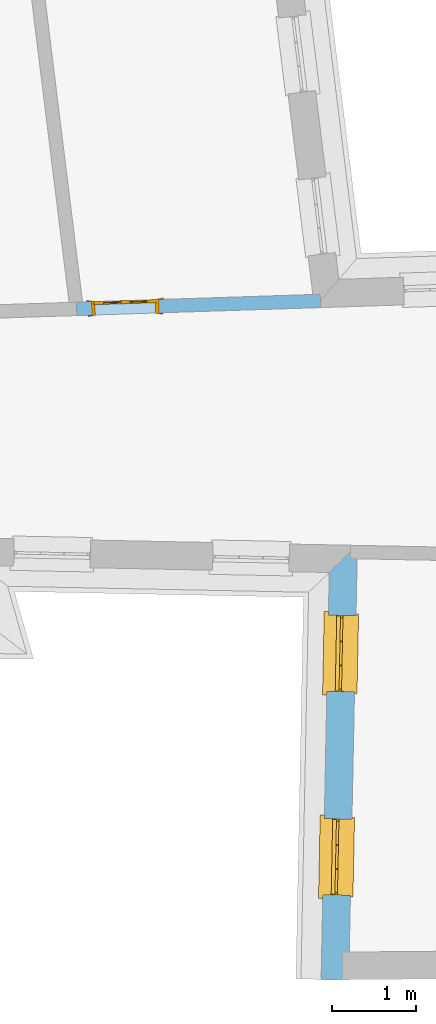
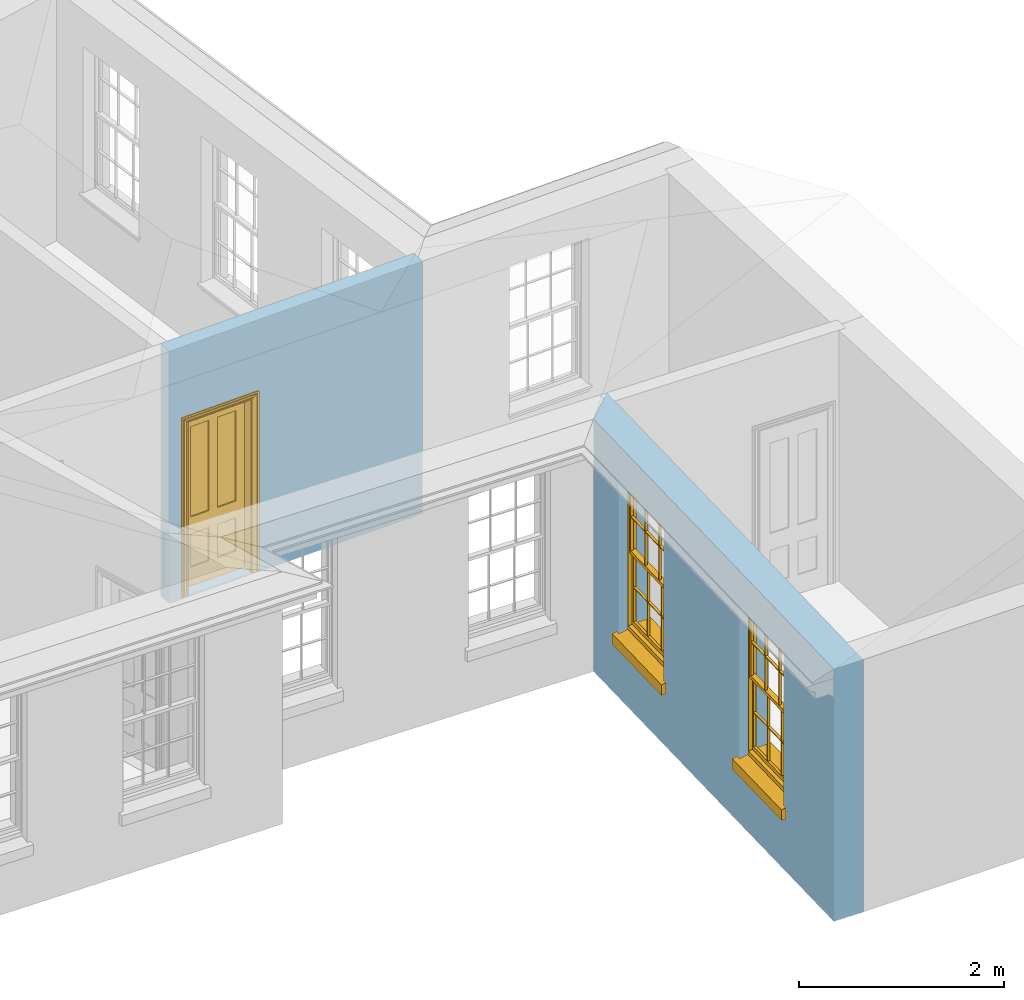
# One storey, part 5 of 11: 2 windows, 1 door, 3 openings, plus 2 elements that do not belong to this part.
"""IFC2X3 building model written with IfcOpenShell, lengths in metres."""

import ifcopenshell
import ifcopenshell.guid

model = None  # the IFC model being written
_history = None  # IfcOwnerHistory: only IFC2X3 demands one
_inside = {}  # id of a spatial element -> (the spatial element, [elements in it])
_under = {}  # id of a project, library or spatial element -> (it, [spatial elements below it])
_declared = {}  # id of a project -> (the project, [libraries it declares])
_typed = {}  # id of a type object -> (the type object, [elements of that type])
_made_of = {}  # id of a material, layer set ... -> (it, [elements and type objects made of it])


def new_model(schema):
    """Start an empty IFC model of exactly this schema.

    Asked for "IFC4X3", IfcOpenShell would pick the latest addendum, in which some entities
    have other attributes; the version numbers below select the first issue.
    IFC2X3 requires an IfcOwnerHistory on every rooted entity: one is made here for all.
    """
    global model, _history
    if schema == "IFC4X3":
        model = ifcopenshell.file(schema_version=(4, 3, 0, 0))
    else:
        model = ifcopenshell.file(schema=schema)
    _inside.clear()
    _under.clear()
    _declared.clear()
    _typed.clear()
    _made_of.clear()
    _history = None
    if model.schema == "IFC2X3":
        org = make("IfcOrganization", Name="unknown")
        user = make(
            "IfcPersonAndOrganization",
            ThePerson=make("IfcPerson", FamilyName="unknown"),
            TheOrganization=org,
        )
        app = make(
            "IfcApplication",
            ApplicationDeveloper=org,
            Version="unknown",
            ApplicationFullName="unknown",
            ApplicationIdentifier="unknown",
        )
        _history = make(
            "IfcOwnerHistory",
            OwningUser=user,
            OwningApplication=app,
            ChangeAction="ADDED",
            CreationDate=0,
        )
    return model


def make(cls, **values):
    """One entity of the class cls with the attributes given. An attribute that is None is left unset."""
    return model.create_entity(
        cls, **{name: value for name, value in values.items() if value is not None}
    )


def rooted(cls, **values):
    """An entity with a GlobalId (a new one), such as an element, a storey or a relation."""
    return make(cls, GlobalId=ifcopenshell.guid.new(), OwnerHistory=_history, **values)


def si_unit(unit_type, name, prefix=None):
    """IfcSIUnit, for example si_unit("LENGTHUNIT", "METRE", prefix="MILLI")."""
    return make("IfcSIUnit", UnitType=unit_type, Prefix=prefix, Name=name)


def assignment(units):
    """IfcUnitAssignment: the units of a project."""
    return None if units is None else make("IfcUnitAssignment", Units=units)


def point(xyz):
    """IfcCartesianPoint."""
    return None if xyz is None else make("IfcCartesianPoint", Coordinates=xyz)


def direction(xyz):
    """IfcDirection."""
    return None if xyz is None else make("IfcDirection", DirectionRatios=xyz)


def frame(location, z_axis=None, x_axis=None):
    """IfcAxis2Placement3D, a coordinate frame: its origin and axes. An axis left out is left unset."""
    return make(
        "IfcAxis2Placement3D",
        Location=point(location),
        Axis=direction(z_axis),
        RefDirection=direction(x_axis),
    )


def origin():
    """The frame at (0, 0, 0) with its axes left unset."""
    return frame((0.0, 0.0, 0.0))


def place(relative_to, where):
    """IfcLocalPlacement: puts the frame where relative to a parent placement (None: the world)."""
    return make(
        "IfcLocalPlacement", PlacementRelTo=relative_to, RelativePlacement=where
    )


def context(
    kind, dimensions, precision=None, world=None, true_north=None, identifier=None
):
    """IfcGeometricRepresentationContext, for example the 3D "Model" context."""
    return make(
        "IfcGeometricRepresentationContext",
        ContextIdentifier=identifier,
        ContextType=kind,
        CoordinateSpaceDimension=dimensions,
        Precision=precision,
        WorldCoordinateSystem=world,
        TrueNorth=true_north,
    )


def subcontext(parent, identifier, kind, view, scale=None):
    """IfcGeometricRepresentationSubContext, for example "Body" below "Model"."""
    return make(
        "IfcGeometricRepresentationSubContext",
        ContextIdentifier=identifier,
        ContextType=kind,
        ParentContext=parent,
        TargetScale=scale,
        TargetView=view,
    )


def project(units=None, contexts=None):
    """IfcProject with its units and contexts."""
    return rooted(
        "IfcProject",
        Name="project",
        RepresentationContexts=contexts,
        UnitsInContext=assignment(units),
    )


def spatial(cls, under=None, at=None, **own):
    """A site, building, storey or space (cls), placed at a placement, below another one or the project."""
    s = rooted(cls, ObjectPlacement=at, **own)
    if under is not None:
        _under.setdefault(under.id(), (under, []))[1].append(s)
    return s


def polyline(points):
    """IfcPolyline through the points."""
    return make("IfcPolyline", Points=[point(p) for p in points])


def outline(outer, holes=None, kind="AREA"):
    """IfcArbitraryClosedProfileDef: a profile drawn as a closed curve; with holes, ...WithVoids."""
    if holes is None:
        return make("IfcArbitraryClosedProfileDef", ProfileType=kind, OuterCurve=outer)
    return make(
        "IfcArbitraryProfileDefWithVoids",
        ProfileType=kind,
        OuterCurve=outer,
        InnerCurves=holes,
    )


def extrude(swept, where, along, depth):
    """IfcExtrudedAreaSolid: the profile swept, set in the frame where, extruded along a direction by depth."""
    return make(
        "IfcExtrudedAreaSolid",
        SweptArea=swept,
        Position=where,
        ExtrudedDirection=direction(along),
        Depth=depth,
    )


def faces_of(points, faces, orient=None, outer=None):
    """IfcFace entities. A face is a list of loops; a loop is a list of indices into points, from 0.

    orient and outer hold one flag for each loop. By default every Orientation is true, the
    first loop of a face is its IfcFaceOuterBound and the others are IfcFaceBound.
    """
    made = []
    for i, loops in enumerate(faces):
        bounds = []
        for j, loop in enumerate(loops):
            is_outer = j == 0 if outer is None else outer[i][j]
            bounds.append(
                make(
                    "IfcFaceOuterBound" if is_outer else "IfcFaceBound",
                    Bound=make("IfcPolyLoop", Polygon=[points[k] for k in loop]),
                    Orientation=True if orient is None else orient[i][j],
                )
            )
        made.append(make("IfcFace", Bounds=bounds))
    return made


def faceted_brep(points, faces, orient=None, outer=None, voids=None):
    """IfcFacetedBrep: a solid bounded by flat faces; with voids (closed shells), ...WithVoids."""
    shared = [point(p) for p in points]
    hull = make("IfcClosedShell", CfsFaces=faces_of(shared, faces, orient, outer))
    if voids is None:
        return make("IfcFacetedBrep", Outer=hull)
    return make(
        "IfcFacetedBrepWithVoids",
        Outer=hull,
        Voids=[
            make(cls, CfsFaces=faces_of(shared, fs, o, b)) for cls, fs, o, b in voids
        ],
    )


def shape(context_of_items, identifier, shape_type, items):
    """IfcShapeRepresentation: the items that make up one representation, for example the "Body"."""
    return make(
        "IfcShapeRepresentation",
        ContextOfItems=context_of_items,
        RepresentationIdentifier=identifier,
        RepresentationType=shape_type,
        Items=items,
    )


def material(Name=None, Category=None):
    """IfcMaterial."""
    return make("IfcMaterial", Name=Name, Category=Category)


def layer(
    of_material, thickness, ventilated=None, Name=None, Category=None, Priority=None
):
    """IfcMaterialLayer: one layer of a wall or slab, of a material (None: an air gap)."""
    return make(
        "IfcMaterialLayer",
        Material=of_material,
        LayerThickness=thickness,
        IsVentilated=ventilated,
        Name=Name,
        Category=Category,
        Priority=Priority,
    )


def layer_set(layers, Name=None):
    """IfcMaterialLayerSet."""
    return make("IfcMaterialLayerSet", MaterialLayers=layers, LayerSetName=Name)


def layer_usage(for_layer_set, set_direction, sense, offset, extent=None):
    """IfcMaterialLayerSetUsage: how a layer set lies in its element."""
    return make(
        "IfcMaterialLayerSetUsage",
        ForLayerSet=for_layer_set,
        LayerSetDirection=set_direction,
        DirectionSense=sense,
        OffsetFromReferenceLine=offset,
        ReferenceExtent=extent,
    )


def made_of(thing, what):
    """Note that an element or type object is made of a material, layer set ...; save() writes the relation."""
    if what is not None:
        _made_of.setdefault(what.id(), (what, []))[1].append(thing)
    return thing


def element(
    cls,
    number,
    at=None,
    inside=None,
    cuts=None,
    type_object=None,
    material=None,
    context=None,
    identifier="Body",
    shape_type=None,
    held_by="IfcProductDefinitionShape",
    body=None,
    shapes=None,
    **own,
):
    """One element of the class cls, such as IfcWall. Its Tag is "e" and its number.

    at: its placement. inside: the storey or other place that contains it. cuts: it is an
    opening in that element (IfcRelVoidsElement). A single representation is given by context,
    identifier, shape_type and body (its items); several are given by shapes. held_by: the class
    of the entity that holds the representations. save() writes the other relations.
    """
    e = rooted(cls, Tag="e%d" % number, ObjectPlacement=at, **own)
    if body is not None:
        shapes = [shape(context, identifier, shape_type, body)]
    if shapes is not None:
        e.Representation = make(held_by, Representations=shapes)
    if inside is not None:
        _inside.setdefault(inside.id(), (inside, []))[1].append(e)
    if cuts is not None:
        rooted(
            "IfcRelVoidsElement", RelatingBuildingElement=cuts, RelatedOpeningElement=e
        )
    if type_object is not None:
        _typed.setdefault(type_object.id(), (type_object, []))[1].append(e)
    return made_of(e, material)


def fill(opening, filler):
    """IfcRelFillsElement: the door or window that sits in an opening."""
    return rooted(
        "IfcRelFillsElement",
        RelatingOpeningElement=opening,
        RelatedBuildingElement=filler,
    )


def aggregate(whole, parts):
    """IfcRelAggregates: a whole, such as a stair, and the parts it consists of."""
    return rooted("IfcRelAggregates", RelatingObject=whole, RelatedObjects=parts)


def save(model, path):
    """Write the relations noted so far, then the file.

    IfcRelAggregates (storeys below a building ...), IfcRelContainedInSpatialStructure (elements
    in a storey), IfcRelDefinesByType, IfcRelAssociatesMaterial and IfcRelDeclares: one each for
    every whole, place, type object, material and project.
    """
    for whole, parts in _under.values():
        aggregate(whole, parts)
    for where, things in _inside.values():
        rooted(
            "IfcRelContainedInSpatialStructure",
            RelatedElements=things,
            RelatingStructure=where,
        )
    for kind, things in _typed.values():
        rooted("IfcRelDefinesByType", RelatedObjects=things, RelatingType=kind)
    for what, things in _made_of.values():
        rooted("IfcRelAssociatesMaterial", RelatedObjects=things, RelatingMaterial=what)
    for by, libraries in _declared.values():
        rooted("IfcRelDeclares", RelatingContext=by, RelatedDefinitions=libraries)
    model.write(path)


model = new_model("IFC2X3")

# Units and contexts
model_context = context("Model", 3, world=origin())
body_context = subcontext(model_context, "Body", "Model", "MODEL_VIEW")
ifc_project = project(units=[si_unit("PLANEANGLEUNIT", "RADIAN"), si_unit("MASSUNIT", "GRAM", prefix="KILO"), si_unit("FORCEUNIT", "NEWTON", prefix="KILO"), si_unit("LENGTHUNIT", "METRE")], contexts=[model_context])

# Site, building, storey
site_placement = place(None, origin())
site = spatial("IfcSite", under=ifc_project, at=site_placement, CompositionType="ELEMENT")
building_placement = place(None, origin())
building = spatial("IfcBuilding", under=site, at=building_placement, Name="Building plot-10", CompositionType="ELEMENT")
storey_placement = place(None, frame((0.0, 0.0, 4.6)))
storey = spatial("IfcBuildingStorey", under=building, at=storey_placement, Name="Floor 1", CompositionType="ELEMENT", Elevation=4.6)

# Wall, openings, windows
ifc_material_1 = material(Name="Masonry")
ifc_layer_1 = layer(ifc_material_1, 0.33, ventilated=False)
ifc_layer_set_1 = layer_set([ifc_layer_1], Name="My Wall")
ifc_layer_usage_1 = layer_usage(ifc_layer_set_1, "AXIS2", "NEGATIVE", 0.08)
wall_1_placement = place(storey_placement, origin())
wall_1 = element("IfcWallStandardCase", 1, at=wall_1_placement, inside=storey, material=ifc_layer_usage_1, Name="exterior", context=body_context, shape_type="SweptSolid", body=[
    extrude(outline(polyline([(51.0054015240496, 17.2553934156152), (50.6688922402643, 16.9320337058085), (50.5723302195108, 12.0863798802376), (50.9022647163068, 12.0798050932483), (51.0054015240496, 17.2553934156152)])), origin(), (0.0, 0.0, 1.0), 3.0),
])
opening_1_placement = place(storey_placement, frame((0.0, 0.0, 0.75)))
opening_1 = element("IfcOpeningElement", 2, at=opening_1_placement, cuts=wall_1, Name="Opening", ObjectType="Opening", context=body_context, shape_type="SweptSolid", body=[
    extrude(outline(polyline([(50.6587978709166, 16.4254803107527), (50.6406673977038, 15.5156609408), (50.9706018944998, 15.5090861538108), (50.9887323677127, 16.4189055237634), (50.6587978709166, 16.4254803107527)])), origin(), (0.0, 0.0, 1.0), 1.82),
])
opening_2_placement = place(storey_placement, frame((0.0, 0.0, 0.75)))
opening_2 = element("IfcOpeningElement", 3, at=opening_2_placement, cuts=wall_1, Name="Opening", ObjectType="Opening", context=body_context, shape_type="SweptSolid", body=[
    extrude(outline(polyline([(50.6105168605399, 14.0026533979673), (50.592386387327, 13.0928340280146), (50.922320884123, 13.0862592410253), (50.9404513573359, 13.996078610978), (50.6105168605399, 14.0026533979673)])), origin(), (0.0, 0.0, 1.0), 1.82),
])
window_1_placement = place(storey_placement, frame((50.9087482472773, 16.4204994115184, 0.75), z_axis=(0.0, 0.0, 1.0), x_axis=(-0.0181304732128567, -0.909819369952672, 0.0)))
window_1 = element("IfcWindow", 4, at=window_1_placement, inside=storey, Name="toilet outside window", OverallHeight=1.82, OverallWidth=0.91, context=body_context, shape_type="Brep", held_by="IfcProductRepresentation", body=[
    faceted_brep([(0.033125, -0.105, 0.975209), (0.01, -0.105, 0.975209), (0.033125, -0.105, 1.376042), (0.876875, -0.105, 0.975209), (0.876875, -0.105, 1.376042), (0.9, -0.105, 0.975209), (0.876875, -0.105, 1.386042), (0.876875, -0.105, 1.786875), (0.9, -0.105, 1.81), (0.033125, -0.105, 1.786875), (0.033125, -0.105, 1.386042), (0.01, -0.105, 1.81), (0.876875, -0.135, 1.376042), (0.876875, -0.135, 0.975209), (0.9, -0.135, 0.937083), (0.033125, -0.135, 1.786875), (0.01, -0.135, 1.81), (0.033125, -0.135, 1.386042), (0.01, -0.135, 0.937083), (0.033125, -0.135, 0.975209), (0.033125, -0.135, 1.376042), (0.876875, -0.135, 1.786875), (0.876875, -0.135, 1.386042), (0.9, -0.135, 1.81), (0.033125, -0.105, 0.937083), (0.01, -0.105, 0.937083), (0.033125, -0.105, 0.53625), (0.876875, -0.105, 0.937083), (0.876875, -0.105, 0.53625), (0.9, -0.105, 0.937083), (0.876875, -0.105, 0.52625), (0.876875, -0.105, 0.125417), (0.9, -0.105, 0.077167), (0.033125, -0.105, 0.125417), (0.033125, -0.105, 0.52625), (0.01, -0.105, 0.077167), (-0.0425, -0.25, 0.01), (-0.0425, -0.3, 0.001667), (0.0, -0.25, 0.01), (0.9525, -0.25, 0.01), (0.91, -0.25, 0.01), (0.9525, -0.3, 0.001667), (-0.02, 0.08, 0.077167), (0.0, 0.08, 0.077167), (-0.02, 0.11, 0.077167), (0.0, -0.06, 0.077167), (0.01, -0.06, 0.077167), (0.91, -0.06, 0.077167), (0.91, 0.08, 0.077167), (0.9, -0.06, 0.077167), (0.93, 0.08, 0.077167), (0.93, 0.11, 0.077167), (0.01, -0.075, 0.975209), (0.9, -0.075, 0.975209), (0.876875, -0.075, 0.125417), (0.876875, -0.075, 0.52625), (0.9, -0.075, 0.077167), (0.876875, -0.075, 0.53625), (0.876875, -0.075, 0.937083), (0.033125, -0.075, 0.125417), (0.01, -0.075, 0.077167), (0.033125, -0.075, 0.52625), (0.033125, -0.075, 0.937083), (0.033125, -0.075, 0.53625), (-0.02, 0.08, 0.052167), (-0.02, 0.11, 0.052167), (0.93, 0.11, 0.052167), (0.93, 0.08, 0.052167), (0.91, 0.08, 0.052167), (0.0, 0.08, 0.052167), (0.91, -0.15, 0.026667), (0.0, -0.15, 0.026667), (-0.0425, -0.3, -0.123333), (0.9525, -0.3, -0.123333), (-0.0425, -0.25, -0.123333), (0.9525, -0.25, -0.123333), (0.01, -0.06, 1.81), (0.9, -0.06, 1.81), (0.0, -0.06, 1.82), (0.91, -0.06, 1.82), (0.01, -0.15, 0.077167), (0.9, -0.15, 0.077167), (0.592292, -0.105, 0.125417), (0.592292, -0.075, 0.125417), (0.317708, -0.075, 0.125417), (0.317708, -0.105, 0.125417), (0.592292, -0.105, 0.53625), (0.317708, -0.105, 0.53625), (0.317708, -0.105, 0.52625), (0.592292, -0.105, 0.52625), (0.592292, -0.075, 0.53625), (0.317708, -0.075, 0.53625), (0.592292, -0.135, 1.386042), (0.592292, -0.105, 1.386042), (0.317708, -0.105, 1.386042), (0.317708, -0.135, 1.386042), (0.317708, -0.135, 1.376042), (0.592292, -0.135, 1.376042), (0.317708, -0.105, 1.376042), (0.592292, -0.105, 1.376042), (0.602292, -0.135, 1.376042), (0.592292, -0.135, 0.975209), (0.602292, -0.135, 0.975209), (0.602292, -0.105, 0.975209), (0.592292, -0.105, 0.975209), (0.602292, -0.105, 1.376042), (0.602292, -0.075, 0.53625), (0.602292, -0.105, 0.53625), (0.317708, -0.075, 0.52625), (0.307708, -0.075, 0.125417), (0.307708, -0.075, 0.52625), (0.602292, -0.075, 0.52625), (0.602292, -0.075, 0.125417), (0.592292, -0.075, 0.52625), (0.307708, -0.075, 0.53625), (0.317708, -0.075, 0.937083), (0.307708, -0.075, 0.937083), (0.602292, -0.075, 0.937083), (0.592292, -0.075, 0.937083), (0.307708, -0.105, 0.52625), (0.307708, -0.105, 0.125417), (0.307708, -0.105, 0.53625), (0.307708, -0.105, 0.937083), (0.592292, -0.105, 0.937083), (0.317708, -0.105, 0.937083), (0.602292, -0.105, 0.937083), (0.602292, -0.105, 0.52625), (0.602292, -0.105, 0.125417), (0.307708, -0.135, 1.386042), (0.307708, -0.135, 1.376042), (0.307708, -0.135, 0.975209), (0.317708, -0.135, 0.975209), (0.317708, -0.135, 1.786875), (0.307708, -0.135, 1.786875), (0.602292, -0.135, 1.786875), (0.592292, -0.135, 1.786875), (0.602292, -0.135, 1.386042), (0.602292, -0.105, 1.386042), (0.307708, -0.105, 1.386042), (0.307708, -0.105, 1.786875), (0.317708, -0.105, 1.786875), (0.592292, -0.105, 1.786875), (0.602292, -0.105, 1.786875), (0.307708, -0.105, 1.376042), (0.317708, -0.105, 0.975209), (0.307708, -0.105, 0.975209), (0.91, -0.15, 1.82), (0.9, -0.15, 1.81), (0.01, -0.15, 1.81), (0.0, -0.15, 1.82), (0.91, -0.25, 0.0), (0.0, -0.25, 0.0), (0.91, 0.08, 0.0), (0.0, 0.08, 0.0)], [[[0, 1, 2]], [[3, 4, 5]], [[6, 7, 8]], [[9, 10, 11]], [[12, 13, 14]], [[15, 16, 17]], [[18, 19, 20]], [[21, 22, 23]], [[24, 25, 26]], [[27, 28, 29]], [[30, 31, 32]], [[33, 34, 35]], [[14, 27, 29]], [[25, 24, 18]], [[36, 37, 38]], [[39, 40, 41]], [[42, 43, 44]], [[45, 46, 43]], [[47, 48, 49]], [[50, 51, 48]], [[1, 0, 52]], [[5, 53, 3]], [[54, 55, 56]], [[57, 58, 53]], [[59, 60, 61]], [[62, 63, 52]], [[48, 43, 46, 49]], [[51, 44, 43, 48]], [[64, 42, 44, 65]], [[65, 44, 51, 66]], [[66, 51, 50, 67]], [[65, 66, 68, 69]], [[60, 56, 49, 46]], [[70, 71, 38, 40]], [[37, 41, 40, 38]], [[37, 72, 73, 41]], [[74, 75, 73, 72]], [[8, 11, 76, 77]], [[76, 78, 79, 77]], [[32, 35, 80, 81]], [[81, 80, 71, 70]], [[82, 83, 84, 85]], [[86, 87, 88, 89]], [[86, 90, 91, 87]], [[92, 93, 94, 95]], [[92, 95, 96, 97]], [[96, 98, 99, 97]], [[100, 97, 101, 102]], [[103, 104, 99, 105]], [[97, 99, 104, 101]], [[102, 103, 105, 100]], [[28, 57, 106, 107]], [[108, 84, 109, 110]], [[111, 112, 83, 113]], [[114, 110, 61, 63]], [[90, 113, 108, 91]], [[115, 91, 114, 116]], [[117, 106, 90, 118]], [[111, 106, 57, 55]], [[119, 110, 109, 120]], [[34, 61, 110, 119]], [[89, 113, 83, 82]], [[88, 108, 113, 89]], [[85, 84, 108, 88]], [[121, 114, 63, 26]], [[122, 116, 114, 121]], [[123, 118, 90, 86]], [[87, 91, 115, 124]], [[107, 106, 117, 125]], [[126, 111, 55, 30]], [[127, 112, 111, 126]], [[126, 30, 28, 107]], [[88, 119, 120, 85]], [[126, 89, 82, 127]], [[125, 123, 86, 107]], [[121, 26, 34, 119]], [[124, 122, 121, 87]], [[128, 17, 20, 129]], [[96, 129, 130, 131]], [[132, 133, 128, 95]], [[134, 135, 92, 136]], [[100, 12, 22, 136]], [[137, 6, 4, 105]], [[94, 138, 139, 140]], [[137, 93, 141, 142]], [[99, 98, 94, 93]], [[143, 2, 10, 138]], [[144, 145, 143, 98]], [[129, 143, 145, 130]], [[20, 2, 143, 129]], [[131, 144, 98, 96]], [[128, 138, 10, 17]], [[133, 139, 138, 128]], [[135, 141, 93, 92]], [[95, 94, 140, 132]], [[22, 6, 137, 136]], [[136, 137, 142, 134]], [[100, 105, 4, 12]], [[107, 86, 89, 126]], [[106, 111, 113, 90]], [[91, 108, 110, 114]], [[87, 121, 119, 88]], [[97, 100, 136, 92]], [[129, 96, 95, 128]], [[98, 143, 138, 94]], [[105, 99, 93, 137]], [[131, 101, 104, 144]], [[124, 115, 118, 123]], [[132, 140, 141, 135]], [[120, 109, 59, 33]], [[15, 9, 139, 133]], [[134, 142, 7, 21]], [[31, 54, 112, 127]], [[36, 74, 72, 37]], [[39, 41, 73, 75]], [[18, 14, 101, 131]], [[23, 16, 132, 135]], [[83, 56, 60, 84]], [[52, 53, 118, 115]], [[53, 52, 144, 104]], [[11, 8, 141, 140]], [[14, 18, 124, 123]], [[2, 1, 11, 10]], [[8, 5, 4, 6]], [[57, 53, 56, 55]], [[60, 52, 63, 61]], [[26, 25, 35, 34]], [[32, 29, 28, 30]], [[14, 23, 22, 12]], [[18, 20, 17, 16]], [[19, 0, 2, 20]], [[17, 10, 9, 15]], [[12, 4, 3, 13]], [[21, 7, 6, 22]], [[27, 58, 57, 28]], [[30, 55, 54, 31]], [[33, 59, 61, 34]], [[26, 63, 62, 24]], [[5, 8, 77, 53]], [[76, 11, 1, 52]], [[46, 45, 78, 76]], [[49, 77, 79, 47]], [[70, 146, 147, 81]], [[71, 80, 148, 149]], [[19, 130, 145, 0]], [[102, 13, 3, 103]], [[116, 122, 24, 62]], [[29, 32, 81, 14]], [[80, 35, 25, 18]], [[60, 46, 76, 52]], [[77, 49, 56, 53]], [[23, 14, 81, 147]], [[16, 148, 80, 18]], [[35, 85, 120]], [[120, 33, 35]], [[127, 82, 32]], [[32, 31, 127]], [[32, 82, 85, 35]], [[102, 101, 14]], [[14, 13, 102]], [[18, 131, 130]], [[130, 19, 18]], [[134, 21, 23]], [[23, 135, 134]], [[16, 15, 133]], [[133, 132, 16]], [[11, 140, 139]], [[139, 9, 11]], [[142, 141, 8]], [[8, 7, 142]], [[23, 147, 148, 16]], [[146, 149, 148, 147]], [[52, 115, 116]], [[116, 62, 52]], [[118, 53, 117]], [[58, 117, 53]], [[27, 125, 117, 58]], [[56, 83, 112]], [[112, 54, 56]], [[109, 84, 60]], [[60, 59, 109]], [[125, 27, 14]], [[14, 123, 125]], [[122, 124, 18]], [[18, 24, 122]], [[145, 144, 52]], [[52, 0, 145]], [[103, 3, 53]], [[53, 104, 103]], [[79, 78, 149, 146]], [[78, 45, 71, 149]], [[146, 70, 47, 79]], [[150, 75, 74, 151]], [[68, 66, 67]], [[48, 68, 67, 50]], [[69, 64, 65]], [[42, 64, 69, 43]], [[69, 68, 152, 153]], [[70, 68, 48, 47]], [[150, 152, 68, 70]], [[43, 69, 71, 45]], [[69, 153, 151, 71]], [[152, 150, 151, 153]], [[38, 151, 74, 36]], [[71, 151, 38]], [[39, 75, 150, 40]], [[40, 150, 70]]]),
])
fill(opening_1, window_1)
window_2_placement = place(storey_placement, frame((50.8604672369005, 13.997672498733, 0.75), z_axis=(0.0, 0.0, 1.0), x_axis=(-0.0181304732128567, -0.909819369952672, 0.0)))
window_2 = element("IfcWindow", 5, at=window_2_placement, inside=storey, Name="toilet outside window", OverallHeight=1.82, OverallWidth=0.91, context=body_context, shape_type="Brep", held_by="IfcProductRepresentation", body=[
    faceted_brep([(0.033125, -0.105, 0.975209), (0.01, -0.105, 0.975209), (0.033125, -0.105, 1.376042), (0.876875, -0.105, 0.975209), (0.876875, -0.105, 1.376042), (0.9, -0.105, 0.975209), (0.876875, -0.105, 1.386042), (0.876875, -0.105, 1.786875), (0.9, -0.105, 1.81), (0.033125, -0.105, 1.786875), (0.033125, -0.105, 1.386042), (0.01, -0.105, 1.81), (0.876875, -0.135, 1.376042), (0.876875, -0.135, 0.975209), (0.9, -0.135, 0.937083), (0.033125, -0.135, 1.786875), (0.01, -0.135, 1.81), (0.033125, -0.135, 1.386042), (0.01, -0.135, 0.937083), (0.033125, -0.135, 0.975209), (0.033125, -0.135, 1.376042), (0.876875, -0.135, 1.786875), (0.876875, -0.135, 1.386042), (0.9, -0.135, 1.81), (0.033125, -0.105, 0.937083), (0.01, -0.105, 0.937083), (0.033125, -0.105, 0.53625), (0.876875, -0.105, 0.937083), (0.876875, -0.105, 0.53625), (0.9, -0.105, 0.937083), (0.876875, -0.105, 0.52625), (0.876875, -0.105, 0.125417), (0.9, -0.105, 0.077167), (0.033125, -0.105, 0.125417), (0.033125, -0.105, 0.52625), (0.01, -0.105, 0.077167), (-0.0425, -0.25, 0.01), (-0.0425, -0.3, 0.001667), (0.0, -0.25, 0.01), (0.9525, -0.25, 0.01), (0.91, -0.25, 0.01), (0.9525, -0.3, 0.001667), (-0.02, 0.08, 0.077167), (0.0, 0.08, 0.077167), (-0.02, 0.11, 0.077167), (0.0, -0.06, 0.077167), (0.01, -0.06, 0.077167), (0.91, -0.06, 0.077167), (0.91, 0.08, 0.077167), (0.9, -0.06, 0.077167), (0.93, 0.08, 0.077167), (0.93, 0.11, 0.077167), (0.01, -0.075, 0.975209), (0.9, -0.075, 0.975209), (0.876875, -0.075, 0.125417), (0.876875, -0.075, 0.52625), (0.9, -0.075, 0.077167), (0.876875, -0.075, 0.53625), (0.876875, -0.075, 0.937083), (0.033125, -0.075, 0.125417), (0.01, -0.075, 0.077167), (0.033125, -0.075, 0.52625), (0.033125, -0.075, 0.937083), (0.033125, -0.075, 0.53625), (-0.02, 0.08, 0.052167), (-0.02, 0.11, 0.052167), (0.93, 0.11, 0.052167), (0.93, 0.08, 0.052167), (0.91, 0.08, 0.052167), (0.0, 0.08, 0.052167), (0.91, -0.15, 0.026667), (0.0, -0.15, 0.026667), (-0.0425, -0.3, -0.123333), (0.9525, -0.3, -0.123333), (-0.0425, -0.25, -0.123333), (0.9525, -0.25, -0.123333), (0.01, -0.06, 1.81), (0.9, -0.06, 1.81), (0.0, -0.06, 1.82), (0.91, -0.06, 1.82), (0.01, -0.15, 0.077167), (0.9, -0.15, 0.077167), (0.592292, -0.105, 0.125417), (0.592292, -0.075, 0.125417), (0.317708, -0.075, 0.125417), (0.317708, -0.105, 0.125417), (0.592292, -0.105, 0.53625), (0.317708, -0.105, 0.53625), (0.317708, -0.105, 0.52625), (0.592292, -0.105, 0.52625), (0.592292, -0.075, 0.53625), (0.317708, -0.075, 0.53625), (0.592292, -0.135, 1.386042), (0.592292, -0.105, 1.386042), (0.317708, -0.105, 1.386042), (0.317708, -0.135, 1.386042), (0.317708, -0.135, 1.376042), (0.592292, -0.135, 1.376042), (0.317708, -0.105, 1.376042), (0.592292, -0.105, 1.376042), (0.602292, -0.135, 1.376042), (0.592292, -0.135, 0.975209), (0.602292, -0.135, 0.975209), (0.602292, -0.105, 0.975209), (0.592292, -0.105, 0.975209), (0.602292, -0.105, 1.376042), (0.602292, -0.075, 0.53625), (0.602292, -0.105, 0.53625), (0.317708, -0.075, 0.52625), (0.307708, -0.075, 0.125417), (0.307708, -0.075, 0.52625), (0.602292, -0.075, 0.52625), (0.602292, -0.075, 0.125417), (0.592292, -0.075, 0.52625), (0.307708, -0.075, 0.53625), (0.317708, -0.075, 0.937083), (0.307708, -0.075, 0.937083), (0.602292, -0.075, 0.937083), (0.592292, -0.075, 0.937083), (0.307708, -0.105, 0.52625), (0.307708, -0.105, 0.125417), (0.307708, -0.105, 0.53625), (0.307708, -0.105, 0.937083), (0.592292, -0.105, 0.937083), (0.317708, -0.105, 0.937083), (0.602292, -0.105, 0.937083), (0.602292, -0.105, 0.52625), (0.602292, -0.105, 0.125417), (0.307708, -0.135, 1.386042), (0.307708, -0.135, 1.376042), (0.307708, -0.135, 0.975209), (0.317708, -0.135, 0.975209), (0.317708, -0.135, 1.786875), (0.307708, -0.135, 1.786875), (0.602292, -0.135, 1.786875), (0.592292, -0.135, 1.786875), (0.602292, -0.135, 1.386042), (0.602292, -0.105, 1.386042), (0.307708, -0.105, 1.386042), (0.307708, -0.105, 1.786875), (0.317708, -0.105, 1.786875), (0.592292, -0.105, 1.786875), (0.602292, -0.105, 1.786875), (0.307708, -0.105, 1.376042), (0.317708, -0.105, 0.975209), (0.307708, -0.105, 0.975209), (0.91, -0.15, 1.82), (0.9, -0.15, 1.81), (0.01, -0.15, 1.81), (0.0, -0.15, 1.82), (0.91, -0.25, 0.0), (0.0, -0.25, 0.0), (0.91, 0.08, 0.0), (0.0, 0.08, 0.0)], [[[0, 1, 2]], [[3, 4, 5]], [[6, 7, 8]], [[9, 10, 11]], [[12, 13, 14]], [[15, 16, 17]], [[18, 19, 20]], [[21, 22, 23]], [[24, 25, 26]], [[27, 28, 29]], [[30, 31, 32]], [[33, 34, 35]], [[14, 27, 29]], [[25, 24, 18]], [[36, 37, 38]], [[39, 40, 41]], [[42, 43, 44]], [[45, 46, 43]], [[47, 48, 49]], [[50, 51, 48]], [[1, 0, 52]], [[5, 53, 3]], [[54, 55, 56]], [[57, 58, 53]], [[59, 60, 61]], [[62, 63, 52]], [[48, 43, 46, 49]], [[51, 44, 43, 48]], [[64, 42, 44, 65]], [[65, 44, 51, 66]], [[66, 51, 50, 67]], [[65, 66, 68, 69]], [[60, 56, 49, 46]], [[70, 71, 38, 40]], [[37, 41, 40, 38]], [[37, 72, 73, 41]], [[74, 75, 73, 72]], [[8, 11, 76, 77]], [[76, 78, 79, 77]], [[32, 35, 80, 81]], [[81, 80, 71, 70]], [[82, 83, 84, 85]], [[86, 87, 88, 89]], [[86, 90, 91, 87]], [[92, 93, 94, 95]], [[92, 95, 96, 97]], [[96, 98, 99, 97]], [[100, 97, 101, 102]], [[103, 104, 99, 105]], [[97, 99, 104, 101]], [[102, 103, 105, 100]], [[28, 57, 106, 107]], [[108, 84, 109, 110]], [[111, 112, 83, 113]], [[114, 110, 61, 63]], [[90, 113, 108, 91]], [[115, 91, 114, 116]], [[117, 106, 90, 118]], [[111, 106, 57, 55]], [[119, 110, 109, 120]], [[34, 61, 110, 119]], [[89, 113, 83, 82]], [[88, 108, 113, 89]], [[85, 84, 108, 88]], [[121, 114, 63, 26]], [[122, 116, 114, 121]], [[123, 118, 90, 86]], [[87, 91, 115, 124]], [[107, 106, 117, 125]], [[126, 111, 55, 30]], [[127, 112, 111, 126]], [[126, 30, 28, 107]], [[88, 119, 120, 85]], [[126, 89, 82, 127]], [[125, 123, 86, 107]], [[121, 26, 34, 119]], [[124, 122, 121, 87]], [[128, 17, 20, 129]], [[96, 129, 130, 131]], [[132, 133, 128, 95]], [[134, 135, 92, 136]], [[100, 12, 22, 136]], [[137, 6, 4, 105]], [[94, 138, 139, 140]], [[137, 93, 141, 142]], [[99, 98, 94, 93]], [[143, 2, 10, 138]], [[144, 145, 143, 98]], [[129, 143, 145, 130]], [[20, 2, 143, 129]], [[131, 144, 98, 96]], [[128, 138, 10, 17]], [[133, 139, 138, 128]], [[135, 141, 93, 92]], [[95, 94, 140, 132]], [[22, 6, 137, 136]], [[136, 137, 142, 134]], [[100, 105, 4, 12]], [[107, 86, 89, 126]], [[106, 111, 113, 90]], [[91, 108, 110, 114]], [[87, 121, 119, 88]], [[97, 100, 136, 92]], [[129, 96, 95, 128]], [[98, 143, 138, 94]], [[105, 99, 93, 137]], [[131, 101, 104, 144]], [[124, 115, 118, 123]], [[132, 140, 141, 135]], [[120, 109, 59, 33]], [[15, 9, 139, 133]], [[134, 142, 7, 21]], [[31, 54, 112, 127]], [[36, 74, 72, 37]], [[39, 41, 73, 75]], [[18, 14, 101, 131]], [[23, 16, 132, 135]], [[83, 56, 60, 84]], [[52, 53, 118, 115]], [[53, 52, 144, 104]], [[11, 8, 141, 140]], [[14, 18, 124, 123]], [[2, 1, 11, 10]], [[8, 5, 4, 6]], [[57, 53, 56, 55]], [[60, 52, 63, 61]], [[26, 25, 35, 34]], [[32, 29, 28, 30]], [[14, 23, 22, 12]], [[18, 20, 17, 16]], [[19, 0, 2, 20]], [[17, 10, 9, 15]], [[12, 4, 3, 13]], [[21, 7, 6, 22]], [[27, 58, 57, 28]], [[30, 55, 54, 31]], [[33, 59, 61, 34]], [[26, 63, 62, 24]], [[5, 8, 77, 53]], [[76, 11, 1, 52]], [[46, 45, 78, 76]], [[49, 77, 79, 47]], [[70, 146, 147, 81]], [[71, 80, 148, 149]], [[19, 130, 145, 0]], [[102, 13, 3, 103]], [[116, 122, 24, 62]], [[29, 32, 81, 14]], [[80, 35, 25, 18]], [[60, 46, 76, 52]], [[77, 49, 56, 53]], [[23, 14, 81, 147]], [[16, 148, 80, 18]], [[35, 85, 120]], [[120, 33, 35]], [[127, 82, 32]], [[32, 31, 127]], [[32, 82, 85, 35]], [[102, 101, 14]], [[14, 13, 102]], [[18, 131, 130]], [[130, 19, 18]], [[134, 21, 23]], [[23, 135, 134]], [[16, 15, 133]], [[133, 132, 16]], [[11, 140, 139]], [[139, 9, 11]], [[142, 141, 8]], [[8, 7, 142]], [[23, 147, 148, 16]], [[146, 149, 148, 147]], [[52, 115, 116]], [[116, 62, 52]], [[118, 53, 117]], [[58, 117, 53]], [[27, 125, 117, 58]], [[56, 83, 112]], [[112, 54, 56]], [[109, 84, 60]], [[60, 59, 109]], [[125, 27, 14]], [[14, 123, 125]], [[122, 124, 18]], [[18, 24, 122]], [[145, 144, 52]], [[52, 0, 145]], [[103, 3, 53]], [[53, 104, 103]], [[79, 78, 149, 146]], [[78, 45, 71, 149]], [[146, 70, 47, 79]], [[150, 75, 74, 151]], [[68, 66, 67]], [[48, 68, 67, 50]], [[69, 64, 65]], [[42, 64, 69, 43]], [[69, 68, 152, 153]], [[70, 68, 48, 47]], [[150, 152, 68, 70]], [[43, 69, 71, 45]], [[69, 153, 151, 71]], [[152, 150, 151, 153]], [[38, 151, 74, 36]], [[71, 151, 38]], [[39, 75, 150, 40]], [[40, 150, 70]]]),
])
fill(opening_2, window_2)

# Wall, opening, door
ifc_material_2 = material(Name="Masonry")
ifc_layer_2 = layer(ifc_material_2, 0.16, ventilated=False)
ifc_layer_set_2 = layer_set([ifc_layer_2], Name="My Wall")
ifc_layer_usage_2 = layer_usage(ifc_layer_set_2, "AXIS2", "NEGATIVE", 0.08)
wall_2_placement = place(storey_placement, origin())
wall_2 = element("IfcWallStandardCase", 6, at=wall_2_placement, inside=storey, material=ifc_layer_usage_2, Name="interior", context=body_context, shape_type="SweptSolid", body=[
    extrude(outline(polyline([(47.658622031028, 20.152054432623), (47.6638318559474, 19.9921392747288), (50.566878828731, 20.0867167160446), (50.5616690038116, 20.2466318739388), (47.658622031028, 20.152054432623)])), origin(), (0.0, 0.0, 1.0), 3.0),
])
opening_3_placement = place(storey_placement, frame((0.0, 0.0, 0.0199999999999996)))
opening_3 = element("IfcOpeningElement", 7, at=opening_3_placement, cuts=wall_2, Name="Opening", ObjectType="Opening", context=body_context, shape_type="SweptSolid", body=[
    extrude(outline(polyline([(47.8437364085784, 19.9980003277633), (48.6433121980491, 20.0240494523607), (48.6381023731296, 20.1839646102548), (47.8385265836589, 20.1579154856574), (47.8437364085784, 19.9980003277633)])), origin(), (0.0, 0.0, 1.0), 2.1),
])
door_placement = place(storey_placement, frame((47.8411314961186, 20.0779579067103, 0.0199999999999996), z_axis=(0.0, 0.0, 1.0), x_axis=(0.799575789470708, 0.0260491245974208, 0.0)))
door = element("IfcDoor", 8, at=door_placement, inside=storey, Name="bedroom inside door", OverallHeight=2.1, OverallWidth=0.8, context=body_context, shape_type="Brep", held_by="IfcProductRepresentation", body=[
    faceted_brep([(0.773, 0.08, 1.895), (0.66, 0.08, 1.895), (0.66, 0.08, 2.073), (0.773, 0.08, 2.073), (0.773, 0.08, 0.82), (0.66, 0.08, 0.82), (0.45, 0.08, 1.895), (0.45, 0.08, 2.073), (0.773, 0.08, 0.62), (0.66, 0.08, 0.62), (0.66, 0.065, 0.82), (0.66, 0.065, 1.895), (0.45, 0.065, 1.895), (0.35, 0.08, 1.895), (0.35, 0.08, 2.073), (0.773, 0.08, 0.225), (0.66, 0.08, 0.225), (0.45, 0.08, 0.62), (0.45, 0.08, 0.82), (0.45, 0.065, 0.82), (0.35, 0.08, 0.82), (0.14, 0.08, 2.073), (0.14, 0.08, 1.895), (0.773, 0.08, 0.0), (0.66, 0.08, 0.0), (0.66, 0.065, 0.225), (0.66, 0.065, 0.62), (0.45, 0.065, 0.62), (0.35, 0.08, 0.62), (0.35, 0.065, 0.82), (0.35, 0.065, 1.895), (0.14, 0.065, 1.895), (0.027, 0.08, 2.073), (0.027, 0.08, 1.895), (0.773, 0.042, 0.0), (0.66, 0.042, 0.0), (0.45, 0.08, 0.0), (0.45, 0.08, 0.225), (0.45, 0.065, 0.225), (0.35, 0.08, 0.225), (0.14, 0.08, 0.82), (0.14, 0.08, 0.62), (0.14, 0.065, 0.82), (0.027, 0.08, 0.82), (0.773, 0.042, 0.225), (0.66, 0.042, 0.225), (0.45, 0.042, 0.0), (0.35, 0.08, 0.0), (0.35, 0.065, 0.225), (0.35, 0.065, 0.62), (0.14, 0.065, 0.62), (0.027, 0.08, 0.62), (0.773, 0.042, 0.62), (0.66, 0.042, 0.62), (0.45, 0.042, 0.225), (0.35, 0.042, 0.0), (0.14, 0.08, 0.225), (0.14, 0.08, 0.0), (0.14, 0.065, 0.225), (0.027, 0.08, 0.225), (0.773, 0.042, 0.82), (0.66, 0.042, 0.82), (0.66, 0.057, 0.62), (0.66, 0.057, 0.225), (0.45, 0.057, 0.225), (0.35, 0.042, 0.225), (0.14, 0.042, 0.0), (0.027, 0.08, 0.0), (0.773, 0.042, 1.895), (0.66, 0.042, 1.895), (0.45, 0.042, 0.62), (0.45, 0.042, 0.82), (0.45, 0.057, 0.62), (0.35, 0.042, 0.62), (0.14, 0.042, 0.225), (0.027, 0.042, 0.0), (0.773, 0.042, 2.073), (0.66, 0.042, 2.073), (0.66, 0.057, 1.895), (0.66, 0.057, 0.82), (0.45, 0.057, 0.82), (0.35, 0.042, 0.82), (0.35, 0.057, 0.62), (0.35, 0.057, 0.225), (0.14, 0.057, 0.225), (0.027, 0.042, 0.225), (0.45, 0.042, 1.895), (0.45, 0.042, 2.073), (0.45, 0.057, 1.895), (0.35, 0.042, 1.895), (0.14, 0.042, 0.82), (0.14, 0.042, 0.62), (0.14, 0.057, 0.62), (0.027, 0.042, 0.62), (0.35, 0.042, 2.073), (0.35, 0.057, 1.895), (0.35, 0.057, 0.82), (0.14, 0.057, 0.82), (0.027, 0.042, 0.82), (0.14, 0.042, 2.073), (0.14, 0.042, 1.895), (0.14, 0.057, 1.895), (0.027, 0.042, 1.895), (0.027, 0.042, 2.073), (0.02, 0.085, 0.0), (0.005, 0.09, 0.0), (0.005, 0.09, 2.095), (0.02, 0.085, 2.08), (0.02, 0.08, 0.0), (0.0, 0.085, 0.0), (0.0, 0.085, 2.1), (0.795, 0.09, 2.095), (0.78, 0.085, 2.08), (0.02, 0.08, 2.08), (0.0, 0.08, 0.0), (-0.032, 0.095, 0.0), (-0.032, 0.095, 2.132), (0.8, 0.085, 2.1), (0.795, 0.09, 0.0), (0.78, 0.085, 0.0), (0.78, 0.08, 2.08), (0.04, 0.04, 0.0), (0.025, 0.04, 0.0), (0.025, 0.04, 2.075), (0.04, 0.04, 2.06), (-0.04, 0.09, 0.0), (-0.04, 0.09, 2.14), (0.832, 0.095, 2.132), (0.8, 0.085, 0.0), (0.78, 0.08, 0.0), (0.8, 0.08, 0.0), (0.86, 0.08, 0.0), (0.86, 0.08, 2.16), (0.8, 0.08, 2.1), (-0.06, 0.08, 2.16), (0.0, 0.08, 2.1), (-0.06, 0.08, 0.0), (-0.04, 0.095, 0.0), (-0.04, 0.095, 2.14), (0.84, 0.09, 2.14), (0.832, 0.095, 0.0), (0.84, 0.09, 0.0), (0.86, 0.095, 0.0), (0.86, 0.095, 2.16), (-0.06, 0.095, 2.16), (-0.06, 0.095, 0.0), (0.84, 0.095, 0.0), (0.84, 0.095, 2.14), (-0.025, -0.095, 0.0), (-0.025, -0.09, 0.0), (-0.025, -0.09, 2.125), (-0.025, -0.095, 2.125), (-0.017, -0.095, 0.0), (-0.017, -0.095, 2.117), (0.825, -0.09, 2.125), (0.825, -0.095, 2.125), (0.825, -0.095, 0.0), (0.845, -0.095, 0.0), (-0.045, -0.095, 2.145), (-0.045, -0.095, 0.0), (0.845, -0.095, 2.145), (0.015, -0.085, 0.0), (0.015, -0.085, 2.085), (0.817, -0.095, 2.117), (0.825, -0.09, 0.0), (0.845, -0.08, 0.0), (0.845, -0.08, 2.145), (-0.045, -0.08, 2.145), (-0.045, -0.08, 0.0), (0.02, -0.09, 0.0), (0.02, -0.09, 2.08), (0.785, -0.085, 2.085), (0.817, -0.095, 0.0), (0.8, -0.08, 0.0), (0.8, -0.08, 2.1), (0.0, -0.08, 2.1), (0.0, -0.08, 0.0), (0.035, -0.085, 0.0), (0.035, -0.085, 2.065), (0.78, -0.09, 2.08), (0.785, -0.085, 0.0), (0.775, 0.04, 2.075), (0.76, 0.04, 2.06), (0.035, -0.08, 2.065), (0.035, -0.08, 0.0), (0.765, -0.085, 2.065), (0.78, -0.09, 0.0), (0.765, -0.08, 0.0), (0.765, -0.08, 2.065), (0.765, -0.085, 0.0), (0.04, -0.08, 2.06), (0.04, -0.08, 0.0), (0.76, -0.08, 2.06), (0.76, -0.08, 0.0), (0.76, 0.04, 0.0), (0.775, 0.04, 0.0), (0.025, 0.08, 0.0), (0.025, 0.08, 2.075), (0.775, 0.08, 0.0), (0.775, 0.08, 2.075)], [[[0, 1, 2, 3]], [[1, 0, 4, 5]], [[1, 6, 7, 2]], [[8, 9, 5, 4]], [[1, 5, 10, 11]], [[6, 1, 11, 12]], [[6, 13, 14, 7]], [[15, 16, 9, 8]], [[9, 17, 18, 5]], [[5, 18, 19, 10]], [[10, 19, 12, 11]], [[18, 6, 12, 19]], [[18, 20, 13, 6]], [[21, 14, 13, 22]], [[23, 24, 16, 15]], [[9, 16, 25, 26]], [[17, 9, 26, 27]], [[17, 28, 20, 18]], [[13, 20, 29, 30]], [[22, 13, 30, 31]], [[32, 21, 22, 33]], [[34, 35, 24, 23]], [[24, 36, 37, 16]], [[16, 37, 38, 25]], [[25, 38, 27, 26]], [[37, 17, 27, 38]], [[37, 39, 28, 17]], [[40, 20, 28, 41]], [[20, 40, 42, 29]], [[31, 30, 29, 42]], [[40, 22, 31, 42]], [[33, 22, 40, 43]], [[35, 34, 44, 45]], [[35, 46, 36, 24]], [[36, 47, 39, 37]], [[28, 39, 48, 49]], [[41, 28, 49, 50]], [[43, 40, 41, 51]], [[45, 44, 52, 53]], [[46, 35, 45, 54]], [[46, 55, 47, 36]], [[56, 39, 47, 57]], [[39, 56, 58, 48]], [[50, 49, 48, 58]], [[56, 41, 50, 58]], [[51, 41, 56, 59]], [[53, 52, 60, 61]], [[45, 53, 62, 63]], [[54, 45, 63, 64]], [[55, 46, 54, 65]], [[55, 66, 57, 47]], [[59, 56, 57, 67]], [[61, 60, 68, 69]], [[70, 53, 61, 71]], [[53, 70, 72, 62]], [[72, 64, 63, 62]], [[70, 54, 64, 72]], [[65, 54, 70, 73]], [[65, 74, 66, 55]], [[67, 57, 66, 75]], [[69, 68, 76, 77]], [[61, 69, 78, 79]], [[71, 61, 79, 80]], [[73, 70, 71, 81]], [[65, 73, 82, 83]], [[74, 65, 83, 84]], [[74, 85, 75, 66]], [[86, 69, 77, 87]], [[69, 86, 88, 78]], [[88, 80, 79, 78]], [[86, 71, 80, 88]], [[81, 71, 86, 89]], [[73, 81, 90, 91]], [[73, 91, 92, 82]], [[83, 82, 92, 84]], [[91, 74, 84, 92]], [[91, 93, 85, 74]], [[89, 86, 87, 94]], [[81, 89, 95, 96]], [[90, 81, 96, 97]], [[90, 98, 93, 91]], [[94, 99, 100, 89]], [[89, 100, 101, 95]], [[101, 97, 96, 95]], [[100, 90, 97, 101]], [[100, 102, 98, 90]], [[99, 103, 102, 100]], [[32, 103, 99, 21]], [[102, 103, 32, 33]], [[98, 102, 33, 43]], [[21, 99, 94, 14]], [[94, 87, 7, 14]], [[7, 87, 77, 2]], [[76, 3, 2, 77]], [[43, 51, 93, 98]], [[51, 59, 85, 93]], [[67, 75, 85, 59]], [[34, 23, 15, 44]], [[44, 15, 8, 52]], [[52, 8, 4, 60]], [[0, 68, 60, 4]], [[0, 3, 76, 68]], [[104, 105, 106, 107]], [[104, 108, 109, 105]], [[105, 109, 110, 106]], [[107, 106, 111, 112]], [[107, 113, 108, 104]], [[114, 109, 108]], [[109, 115, 116, 110]], [[106, 110, 117, 111]], [[112, 111, 118, 119]], [[113, 107, 112, 120]], [[121, 122, 123, 124]], [[115, 109, 114, 125]], [[115, 125, 126, 116]], [[110, 116, 127, 117]], [[111, 117, 128, 118]], [[118, 128, 129, 119]], [[120, 112, 119, 129]], [[130, 129, 128]], [[130, 131, 132, 133]], [[133, 132, 134, 135]], [[135, 134, 136, 114]], [[136, 125, 114]], [[125, 137, 138, 126]], [[116, 126, 139, 127]], [[117, 127, 140, 128]], [[141, 130, 128, 140]], [[131, 130, 141]], [[131, 142, 143, 132]], [[132, 143, 144, 134]], [[134, 144, 145, 136]], [[137, 125, 136, 145]], [[143, 142, 146]], [[143, 146, 147]], [[137, 145, 144]], [[143, 147, 138]], [[138, 137, 144]], [[143, 138, 144]], [[126, 138, 147, 139]], [[127, 139, 141, 140]], [[142, 131, 141, 146]], [[139, 147, 146, 141]], [[148, 149, 150, 151]], [[149, 152, 153, 150]], [[151, 150, 154, 155]], [[155, 156, 157]], [[158, 159, 148]], [[158, 148, 151]], [[155, 157, 160]], [[158, 151, 155]], [[155, 160, 158]], [[152, 161, 162, 153]], [[150, 153, 163, 154]], [[155, 154, 164, 156]], [[156, 164, 165, 157]], [[157, 165, 166, 160]], [[160, 166, 167, 158]], [[158, 167, 168, 159]], [[161, 169, 170, 162]], [[153, 162, 171, 163]], [[154, 163, 172, 164]], [[165, 164, 173]], [[165, 173, 174, 166]], [[166, 174, 175, 167]], [[167, 175, 176, 168]], [[169, 177, 178, 170]], [[162, 170, 179, 171]], [[163, 171, 180, 172]], [[172, 180, 173, 164]], [[124, 123, 181, 182]], [[183, 178, 177, 184]], [[170, 178, 185, 179]], [[171, 179, 186, 180]], [[187, 173, 180]], [[185, 188, 187, 189]], [[188, 185, 178, 183]], [[179, 185, 189, 186]], [[189, 187, 180, 186]], [[190, 183, 184, 191]], [[192, 188, 183, 190]], [[191, 184, 122, 121]], [[124, 190, 191, 121]], [[193, 187, 188, 192]], [[182, 192, 190, 124]], [[184, 176, 122]], [[194, 195, 187, 193]], [[192, 182, 194, 193]], [[161, 176, 184]], [[114, 108, 122, 176]], [[173, 187, 195]], [[152, 149, 176, 161]], [[169, 161, 184, 177]], [[196, 122, 108]], [[176, 175, 135, 114]], [[173, 195, 129, 130]], [[176, 149, 168]], [[123, 122, 196, 197]], [[196, 108, 113, 197]], [[175, 174, 133, 135]], [[198, 129, 195]], [[133, 174, 173, 130]], [[159, 168, 149, 148]], [[181, 123, 197, 199]], [[197, 113, 120, 199]], [[199, 120, 129, 198]], [[195, 181, 199, 198]], [[195, 194, 182, 181]]]),
])
fill(opening_3, door)

save(model, "model.ifc")
